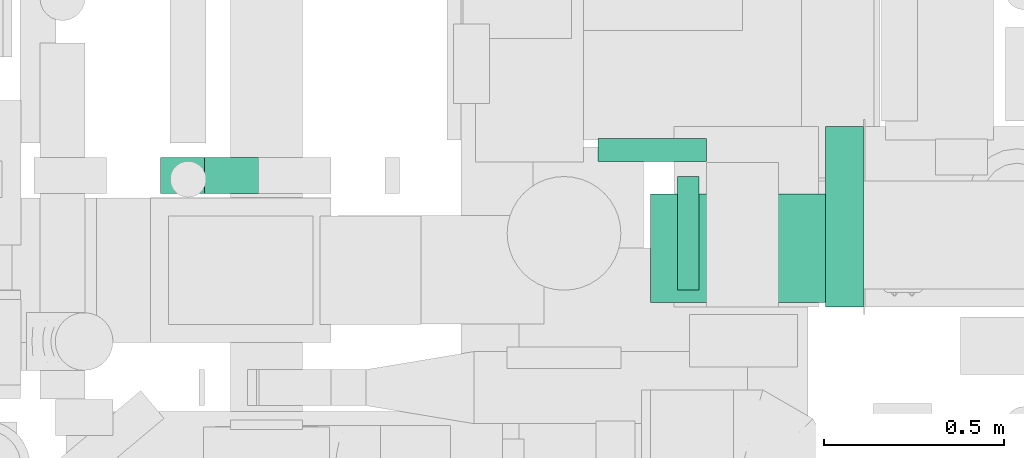
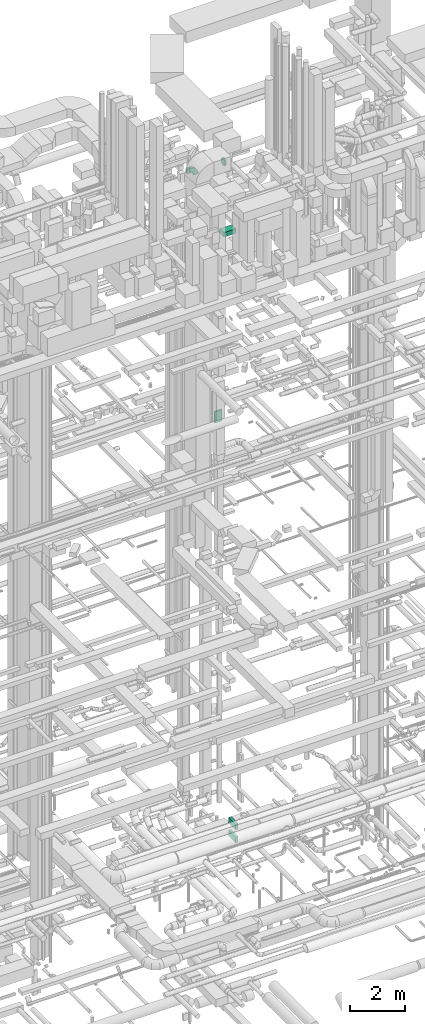
# One storey, part 200 of 337: 6 flow segments, 1 flow fitting.
"""IFC2X3 building model written with IfcOpenShell, lengths in millimetres."""

from ifc_helpers import new_model, entity, si_unit, converted_unit, derived_unit, direction, frame, frame_2d, origin, origin_2d_with_axis, place, context, subcontext, project, spatial, polyline, circle_curve, parameter, trimmed, segment, composite_curve, rectangle, circle, outline, extrude, source, transform, mapped, material, type_object, type_shapes, element, save


model = new_model("IFC2X3")

# Units and contexts
model_context = context("Model", 3, precision=0.01, world=origin(), true_north=direction((6.12303176911189e-17, 1.0)))
body_context = subcontext(model_context, "Body", "Model", "MODEL_VIEW")
ifc_project = project(units=[si_unit("LENGTHUNIT", "METRE", prefix="MILLI"), si_unit("AREAUNIT", "SQUARE_METRE"), si_unit("VOLUMEUNIT", "CUBIC_METRE"), converted_unit("PLANEANGLEUNIT", "DEGREE", entity("IfcRatioMeasure", 0.0174532925199433), si_unit("PLANEANGLEUNIT", "RADIAN"), dimensions=[0, 0, 0, 0, 0, 0, 0]), si_unit("MASSUNIT", "GRAM", prefix="KILO"), derived_unit("MASSDENSITYUNIT", [(si_unit("MASSUNIT", "GRAM", prefix="KILO"), 1), (si_unit("LENGTHUNIT", "METRE"), -3)]), derived_unit("MOMENTOFINERTIAUNIT", [(si_unit("LENGTHUNIT", "METRE"), 4)]), si_unit("TIMEUNIT", "SECOND"), si_unit("FREQUENCYUNIT", "HERTZ"), si_unit("THERMODYNAMICTEMPERATUREUNIT", "DEGREE_CELSIUS"), derived_unit("THERMALTRANSMITTANCEUNIT", [(si_unit("MASSUNIT", "GRAM", prefix="KILO"), 1), (si_unit("THERMODYNAMICTEMPERATUREUNIT", "KELVIN"), -1), (si_unit("TIMEUNIT", "SECOND"), -3)]), derived_unit("VOLUMETRICFLOWRATEUNIT", [(si_unit("LENGTHUNIT", "METRE"), 3), (si_unit("TIMEUNIT", "SECOND"), -1)]), derived_unit("MASSFLOWRATEUNIT", [(si_unit("MASSUNIT", "GRAM", prefix="KILO"), 1), (si_unit("TIMEUNIT", "SECOND"), -1)]), derived_unit("ROTATIONALFREQUENCYUNIT", [(si_unit("TIMEUNIT", "SECOND"), -1)]), si_unit("ELECTRICCURRENTUNIT", "AMPERE"), si_unit("ELECTRICVOLTAGEUNIT", "VOLT"), si_unit("POWERUNIT", "WATT"), si_unit("FORCEUNIT", "NEWTON", prefix="KILO"), si_unit("ILLUMINANCEUNIT", "LUX"), si_unit("LUMINOUSFLUXUNIT", "LUMEN"), si_unit("LUMINOUSINTENSITYUNIT", "CANDELA"), derived_unit("USERDEFINED", [(si_unit("MASSUNIT", "GRAM", prefix="KILO"), -1), (si_unit("LENGTHUNIT", "METRE"), -2), (si_unit("TIMEUNIT", "SECOND"), 3), (si_unit("LUMINOUSFLUXUNIT", "LUMEN"), 1)]), derived_unit("LINEARVELOCITYUNIT", [(si_unit("LENGTHUNIT", "METRE"), 1), (si_unit("TIMEUNIT", "SECOND"), -1)]), si_unit("PRESSUREUNIT", "PASCAL"), derived_unit("USERDEFINED", [(si_unit("LENGTHUNIT", "METRE"), -2), (si_unit("MASSUNIT", "GRAM", prefix="KILO"), 1), (si_unit("TIMEUNIT", "SECOND"), -2)]), derived_unit("LINEARFORCEUNIT", [(si_unit("MASSUNIT", "GRAM", prefix="KILO"), 1), (si_unit("LENGTHUNIT", "METRE"), 1), (si_unit("TIMEUNIT", "SECOND"), -2), (si_unit("LENGTHUNIT", "METRE"), -1)]), derived_unit("PLANARFORCEUNIT", [(si_unit("MASSUNIT", "GRAM", prefix="KILO"), 1), (si_unit("LENGTHUNIT", "METRE"), 1), (si_unit("TIMEUNIT", "SECOND"), -2), (si_unit("LENGTHUNIT", "METRE"), -2)])], contexts=[model_context])

# Site, building, storey
site_placement = place(None, origin())
site = spatial("IfcSite", under=ifc_project, at=site_placement, CompositionType="ELEMENT")
building_placement = place(site_placement, origin())
building = spatial("IfcBuilding", under=site, at=building_placement, CompositionType="ELEMENT")
storey_placement = place(building_placement, origin())
storey = spatial("IfcBuildingStorey", under=building, at=storey_placement, CompositionType="ELEMENT", Elevation=0.0)

# Flow segments
duct_segment_type_1 = type_object("IfcDuctSegmentType", PredefinedType="NOTDEFINED")
flow_segment_1_placement = place(storey_placement, frame((53490.04, 13092.39, 18900.0)))
element("IfcFlowSegment", 1, at=flow_segment_1_placement, inside=storey, type_object=duct_segment_type_1, context=body_context, shape_type="SweptSolid", body=[
    extrude(rectangle(XDim=63.7499999999617, YDim=300.000000000001, at=origin_2d_with_axis()), frame((150.0, 31.88, 0.0), z_axis=(0.0, 0.0, 1.0), x_axis=(0.0, -1.0, 0.0)), (0.0, 0.0, 1.0), 499.999999999999),
])
flow_segment_2_placement = place(storey_placement, frame((53635.82, 12702.02, 27300.0)))
element("IfcFlowSegment", 2, at=flow_segment_2_placement, inside=storey, type_object=duct_segment_type_1, context=body_context, shape_type="SweptSolid", body=[
    extrude(rectangle(XDim=499.99999999999, YDim=300.000000000001, at=origin_2d_with_axis()), frame((250.0, 150.0, 0.0)), (0.0, 0.0, 1.0), 199.999999999998),
])
flow_segment_3_placement = place(storey_placement, frame((52278.13, 13003.66, 30390.0)))
element("IfcFlowSegment", 3, at=flow_segment_3_placement, inside=storey, type_object=duct_segment_type_1, context=body_context, shape_type="SweptSolid", body=[
    extrude(rectangle(XDim=121.613165855175, YDim=100.000000000001, at=origin_2d_with_axis()), frame((60.81, 50.0, 0.0), z_axis=(0.0, 0.0, 1.0), x_axis=(-1.0, 0.0, 0.0)), (0.0, 0.0, 1.0), 199.999999999998),
])
for number, where in (
    (4, (54120.03, 12689.46, 975.0)),
    (5, (54120.03, 12689.46, 400.0)),
):
    element("IfcFlowSegment", number, at=place(storey_placement, frame(where)), inside=storey, type_object=duct_segment_type_1, context=body_context, shape_type="SweptSolid", body=[
        extrude(rectangle(XDim=105.078059999927, YDim=499.999999999999, at=origin_2d_with_axis()), frame((52.54, 250.0, 0.0), z_axis=(0.0, 0.0, 1.0), x_axis=(-1.0, 0.0, 0.0)), (0.0, 0.0, 1.0), 250.0),
    ])
duct_segment_type_2 = type_object("IfcDuctSegmentType", PredefinedType="NOTDEFINED")
flow_segment_4_placement = place(storey_placement, frame((53710.67, 12734.42, 30330.46)))
element("IfcFlowSegment", 6, at=flow_segment_4_placement, inside=storey, type_object=duct_segment_type_2, context=body_context, shape_type="SweptSolid", body=[
    extrude(circle(Radius=157.5, at=origin_2d_with_axis()), frame((0.0, 159.1, 159.1), z_axis=(1.0, 0.0, 0.0), x_axis=(0.0, -1.0, 0.0)), (0.0, 0.0, 1.0), 59.6065149999954),
])

# Flow fitting
ifc_material = material()
duct_fitting_type = type_object("IfcDuctFittingType", PredefinedType="NOTDEFINED", material=ifc_material)
shared_shape = source(origin(), body_context, "Body", "SweptSolid", [
    extrude(outline(composite_curve([segment(polyline([(-225.0, -125.0), (-25.0, -125.0)]), True, "CONTINUOUS"), segment(trimmed(circle_curve(frame_2d((125.0, -125.0), x_axis=(0.0, 1.0)), 150.0), [parameter(0.0)], [parameter(90.0000000000001)], True, "PARAMETER"), False, "CONTINUOUS"), segment(polyline([(125.0, 25.0), (125.0, 225.0)]), True, "CONTINUOUS"), segment(trimmed(circle_curve(frame_2d((125.0, -125.0), x_axis=(0.0, 1.0)), 350.0), [parameter(0.0)], [parameter(90.0000000000001)], True, "PARAMETER"), True, "CONTINUOUS")], self_intersect=False)), frame((-125.0, 125.0, -50.0), z_axis=(0.0, 0.0, 1.0), x_axis=(-1.0, 0.0, 0.0)), (0.0, 0.0, 1.0), 100.0),
])
type_shapes(duct_fitting_type, [shared_shape])
flow_fitting_placement = place(storey_placement, frame((52649.74, 13053.66, 30490.0), z_axis=(0.0, -1.0, 0.0), x_axis=(0.0, 0.0, 1.0)))
element("IfcFlowFitting", 7, at=flow_fitting_placement, inside=storey, type_object=duct_fitting_type, material=ifc_material, context=body_context, shape_type="MappedRepresentation", body=[
    mapped(shared_shape, transform((0.0, 0.0, 0.0), scale=1.0)),
])

save(model, "model.ifc")
